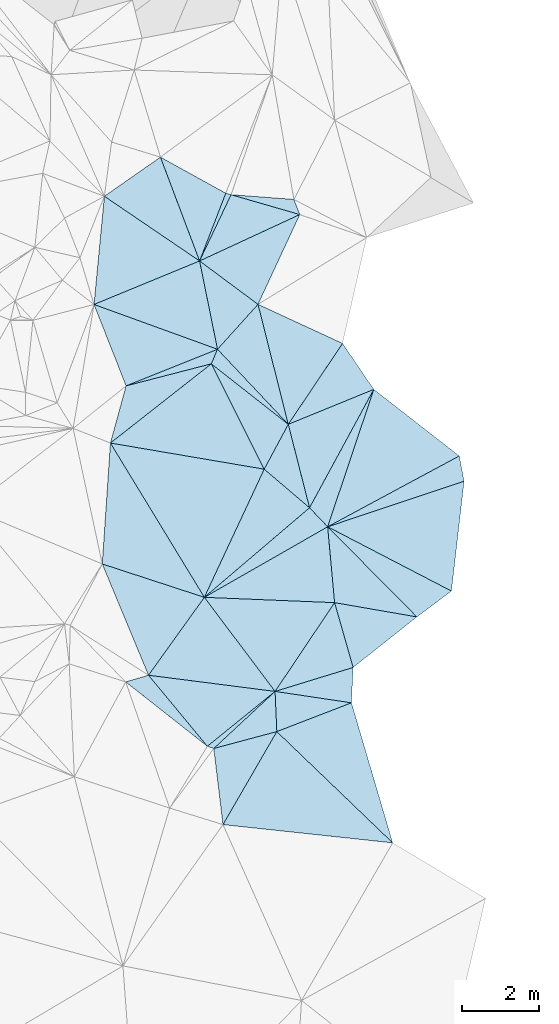
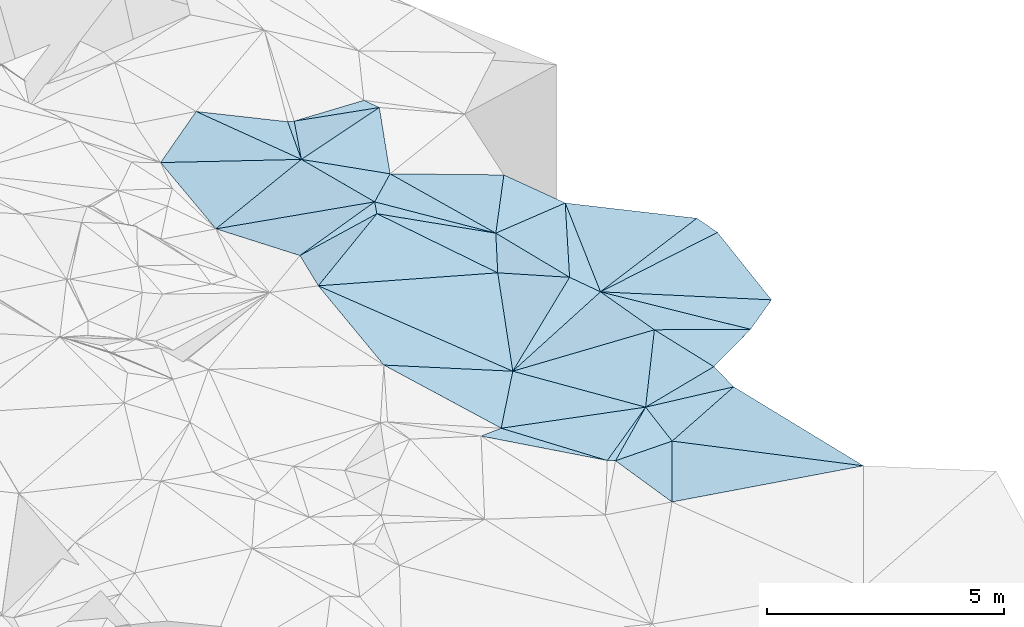
# One storey, part 159 of 275: 45 plates.
"""IFC2X3 building model written with IfcOpenShell, lengths in millimetres."""

import ifcopenshell
import ifcopenshell.guid

model = None  # the IFC model being written
_history = None  # IfcOwnerHistory: only IFC2X3 demands one
_inside = {}  # id of a spatial element -> (the spatial element, [elements in it])
_under = {}  # id of a project, library or spatial element -> (it, [spatial elements below it])
_declared = {}  # id of a project -> (the project, [libraries it declares])
_typed = {}  # id of a type object -> (the type object, [elements of that type])
_made_of = {}  # id of a material, layer set ... -> (it, [elements and type objects made of it])


def new_model(schema):
    """Start an empty IFC model of exactly this schema.

    Asked for "IFC4X3", IfcOpenShell would pick the latest addendum, in which some entities
    have other attributes; the version numbers below select the first issue.
    IFC2X3 requires an IfcOwnerHistory on every rooted entity: one is made here for all.
    """
    global model, _history
    if schema == "IFC4X3":
        model = ifcopenshell.file(schema_version=(4, 3, 0, 0))
    else:
        model = ifcopenshell.file(schema=schema)
    _inside.clear()
    _under.clear()
    _declared.clear()
    _typed.clear()
    _made_of.clear()
    _history = None
    if model.schema == "IFC2X3":
        org = make("IfcOrganization", Name="unknown")
        user = make(
            "IfcPersonAndOrganization",
            ThePerson=make("IfcPerson", FamilyName="unknown"),
            TheOrganization=org,
        )
        app = make(
            "IfcApplication",
            ApplicationDeveloper=org,
            Version="unknown",
            ApplicationFullName="unknown",
            ApplicationIdentifier="unknown",
        )
        _history = make(
            "IfcOwnerHistory",
            OwningUser=user,
            OwningApplication=app,
            ChangeAction="ADDED",
            CreationDate=0,
        )
    return model


def make(cls, **values):
    """One entity of the class cls with the attributes given. An attribute that is None is left unset."""
    return model.create_entity(
        cls, **{name: value for name, value in values.items() if value is not None}
    )


def rooted(cls, **values):
    """An entity with a GlobalId (a new one), such as an element, a storey or a relation."""
    return make(cls, GlobalId=ifcopenshell.guid.new(), OwnerHistory=_history, **values)


def si_unit(unit_type, name, prefix=None):
    """IfcSIUnit, for example si_unit("LENGTHUNIT", "METRE", prefix="MILLI")."""
    return make("IfcSIUnit", UnitType=unit_type, Prefix=prefix, Name=name)


def assignment(units):
    """IfcUnitAssignment: the units of a project."""
    return None if units is None else make("IfcUnitAssignment", Units=units)


def point(xyz):
    """IfcCartesianPoint."""
    return None if xyz is None else make("IfcCartesianPoint", Coordinates=xyz)


def direction(xyz):
    """IfcDirection."""
    return None if xyz is None else make("IfcDirection", DirectionRatios=xyz)


def frame(location, z_axis=None, x_axis=None):
    """IfcAxis2Placement3D, a coordinate frame: its origin and axes. An axis left out is left unset."""
    return make(
        "IfcAxis2Placement3D",
        Location=point(location),
        Axis=direction(z_axis),
        RefDirection=direction(x_axis),
    )


def origin_with_axes():
    """The frame at (0, 0, 0) with the z axis (0, 0, 1) and the x axis (1, 0, 0) written out."""
    return frame((0.0, 0.0, 0.0), z_axis=(0.0, 0.0, 1.0), x_axis=(1.0, 0.0, 0.0))


def place(relative_to, where):
    """IfcLocalPlacement: puts the frame where relative to a parent placement (None: the world)."""
    return make(
        "IfcLocalPlacement", PlacementRelTo=relative_to, RelativePlacement=where
    )


def context(
    kind, dimensions, precision=None, world=None, true_north=None, identifier=None
):
    """IfcGeometricRepresentationContext, for example the 3D "Model" context."""
    return make(
        "IfcGeometricRepresentationContext",
        ContextIdentifier=identifier,
        ContextType=kind,
        CoordinateSpaceDimension=dimensions,
        Precision=precision,
        WorldCoordinateSystem=world,
        TrueNorth=true_north,
    )


def subcontext(parent, identifier, kind, view, scale=None):
    """IfcGeometricRepresentationSubContext, for example "Body" below "Model"."""
    return make(
        "IfcGeometricRepresentationSubContext",
        ContextIdentifier=identifier,
        ContextType=kind,
        ParentContext=parent,
        TargetScale=scale,
        TargetView=view,
    )


def project(units=None, contexts=None):
    """IfcProject with its units and contexts."""
    return rooted(
        "IfcProject",
        Name="project",
        RepresentationContexts=contexts,
        UnitsInContext=assignment(units),
    )


def spatial(cls, under=None, at=None, **own):
    """A site, building, storey or space (cls), placed at a placement, below another one or the project."""
    s = rooted(cls, ObjectPlacement=at, **own)
    if under is not None:
        _under.setdefault(under.id(), (under, []))[1].append(s)
    return s


def polyline(points):
    """IfcPolyline through the points."""
    return make("IfcPolyline", Points=[point(p) for p in points])


def outline(outer, holes=None, kind="AREA"):
    """IfcArbitraryClosedProfileDef: a profile drawn as a closed curve; with holes, ...WithVoids."""
    if holes is None:
        return make("IfcArbitraryClosedProfileDef", ProfileType=kind, OuterCurve=outer)
    return make(
        "IfcArbitraryProfileDefWithVoids",
        ProfileType=kind,
        OuterCurve=outer,
        InnerCurves=holes,
    )


def extrude(swept, where, along, depth):
    """IfcExtrudedAreaSolid: the profile swept, set in the frame where, extruded along a direction by depth."""
    return make(
        "IfcExtrudedAreaSolid",
        SweptArea=swept,
        Position=where,
        ExtrudedDirection=direction(along),
        Depth=depth,
    )


def shape(context_of_items, identifier, shape_type, items):
    """IfcShapeRepresentation: the items that make up one representation, for example the "Body"."""
    return make(
        "IfcShapeRepresentation",
        ContextOfItems=context_of_items,
        RepresentationIdentifier=identifier,
        RepresentationType=shape_type,
        Items=items,
    )


def material(Name=None, Category=None):
    """IfcMaterial."""
    return make("IfcMaterial", Name=Name, Category=Category)


def made_of(thing, what):
    """Note that an element or type object is made of a material, layer set ...; save() writes the relation."""
    if what is not None:
        _made_of.setdefault(what.id(), (what, []))[1].append(thing)
    return thing


def type_object(cls, material=None, **own):
    """A type object (cls), such as IfcWallType, which elements share."""
    return made_of(rooted(cls, **own), material)


def element(
    cls,
    number,
    at=None,
    inside=None,
    cuts=None,
    type_object=None,
    material=None,
    context=None,
    identifier="Body",
    shape_type=None,
    held_by="IfcProductDefinitionShape",
    body=None,
    shapes=None,
    **own,
):
    """One element of the class cls, such as IfcWall. Its Tag is "e" and its number.

    at: its placement. inside: the storey or other place that contains it. cuts: it is an
    opening in that element (IfcRelVoidsElement). A single representation is given by context,
    identifier, shape_type and body (its items); several are given by shapes. held_by: the class
    of the entity that holds the representations. save() writes the other relations.
    """
    e = rooted(cls, Tag="e%d" % number, ObjectPlacement=at, **own)
    if body is not None:
        shapes = [shape(context, identifier, shape_type, body)]
    if shapes is not None:
        e.Representation = make(held_by, Representations=shapes)
    if inside is not None:
        _inside.setdefault(inside.id(), (inside, []))[1].append(e)
    if cuts is not None:
        rooted(
            "IfcRelVoidsElement", RelatingBuildingElement=cuts, RelatedOpeningElement=e
        )
    if type_object is not None:
        _typed.setdefault(type_object.id(), (type_object, []))[1].append(e)
    return made_of(e, material)


def aggregate(whole, parts):
    """IfcRelAggregates: a whole, such as a stair, and the parts it consists of."""
    return rooted("IfcRelAggregates", RelatingObject=whole, RelatedObjects=parts)


def save(model, path):
    """Write the relations noted so far, then the file.

    IfcRelAggregates (storeys below a building ...), IfcRelContainedInSpatialStructure (elements
    in a storey), IfcRelDefinesByType, IfcRelAssociatesMaterial and IfcRelDeclares: one each for
    every whole, place, type object, material and project.
    """
    for whole, parts in _under.values():
        aggregate(whole, parts)
    for where, things in _inside.values():
        rooted(
            "IfcRelContainedInSpatialStructure",
            RelatedElements=things,
            RelatingStructure=where,
        )
    for kind, things in _typed.values():
        rooted("IfcRelDefinesByType", RelatedObjects=things, RelatingType=kind)
    for what, things in _made_of.values():
        rooted("IfcRelAssociatesMaterial", RelatedObjects=things, RelatingMaterial=what)
    for by, libraries in _declared.values():
        rooted("IfcRelDeclares", RelatingContext=by, RelatedDefinitions=libraries)
    model.write(path)


model = new_model("IFC2X3")

# Units and contexts
model_context = context("Model", 3, precision=1e-05, world=origin_with_axes())
body_context = subcontext(model_context, "Body", "Model", "MODEL_VIEW")
ifc_project = project(units=[si_unit("LENGTHUNIT", "METRE", prefix="MILLI"), si_unit("AREAUNIT", "SQUARE_METRE"), si_unit("VOLUMEUNIT", "CUBIC_METRE"), si_unit("MASSUNIT", "GRAM", prefix="KILO"), si_unit("TIMEUNIT", "SECOND"), si_unit("PLANEANGLEUNIT", "RADIAN"), si_unit("SOLIDANGLEUNIT", "STERADIAN"), si_unit("THERMODYNAMICTEMPERATUREUNIT", "DEGREE_CELSIUS"), si_unit("LUMINOUSINTENSITYUNIT", "LUMEN")], contexts=[model_context])

# Site, building, storey
site_placement = place(None, origin_with_axes())
site = spatial("IfcSite", under=ifc_project, at=site_placement, CompositionType="ELEMENT")
building_placement = place(site_placement, origin_with_axes())
building = spatial("IfcBuilding", under=site, at=building_placement, Name="Undefined", CompositionType="ELEMENT")
storey_placement = place(building_placement, origin_with_axes())
storey = spatial("IfcBuildingStorey", under=building, at=storey_placement, Name="Undefined", CompositionType="ELEMENT", Elevation=0.0)

# Plates
ifc_material = material()
plate_type_1 = type_object("IfcPlateType", PredefinedType="NOTDEFINED")
plate_1_placement = place(storey_placement, frame((-33080.2540832994, 129754.297302444, 45919.5141620709), z_axis=(-0.214587577699776, -0.0988065325564838, -0.971694108565606), x_axis=(0.797473107325296, -0.592117404051105, -0.115903506904312)))
element("IfcPlate", 1, at=plate_1_placement, inside=storey, type_object=plate_type_1, material=ifc_material, Name="00", context=body_context, shape_type="SweptSolid", body=[
    extrude(outline(polyline([(0.0, 0.0), (1898.13061523438, -3.92901711165905e-09), (1709.89282226563, 1594.22912597656), (0.0, 0.0)])), frame((-8.85201319254618e-08, 2.18876761149539e-07, -0.5000001331573), z_axis=(0.0, 0.0, 1.0), x_axis=(1.0, 0.0, 0.0)), (0.0, 0.0, 1.0), 1.0),
])
plate_2_placement = place(storey_placement, frame((-27451.008393185, 120533.023808018, 45159.5179466628), z_axis=(-0.247378094575524, -0.0962454606016456, -0.964127009080111), x_axis=(-0.958999822656448, 0.166338762885519, 0.229457525713618)))
element("IfcPlate", 2, at=plate_2_placement, inside=storey, type_object=plate_type_1, material=ifc_material, Name="00", context=body_context, shape_type="SweptSolid", body=[
    extrude(outline(polyline([(0.0, 0.0), (2222.63354492188, 1.30967237055302e-09), (2687.62255859375, 1923.560546875), (0.0, 0.0)])), frame((-8.85201319254618e-08, 2.18876761149539e-07, -0.5000001331573), z_axis=(0.0, 0.0, 1.0), x_axis=(1.0, 0.0, 0.0)), (0.0, 0.0, 1.0), 1.0),
])
plate_type_2 = type_object("IfcPlateType", PredefinedType="NOTDEFINED")
plate_3_placement = place(storey_placement, frame((-32615.5109748001, 127466.84957414, 46049.5017491247), z_axis=(0.0719724589365556, -0.0420154660429778, -0.996521282144951), x_axis=(-0.936910517217906, 0.339816973030889, -0.081994558152361)))
element("IfcPlate", 3, at=plate_3_placement, inside=storey, type_object=plate_type_2, material=ifc_material, Name="00", context=body_context, shape_type="SweptSolid", body=[
    extrude(outline(polyline([(0.0, 0.0), (3414.86083984375, 6.83940015733242e-10), (1223.27099609375, 1992.2119140625), (0.0, 0.0)])), frame((-8.85201319254618e-08, 2.18876761149539e-07, -0.5000001331573), z_axis=(0.0, 0.0, 1.0), x_axis=(1.0, 0.0, 0.0)), (0.0, 0.0, 1.0), 1.0),
])
plate_type_3 = type_object("IfcPlateType", PredefinedType="NOTDEFINED")
plate_4_placement = place(storey_placement, frame((-31079.5214193019, 117562.126037099, 45349.5046864779), z_axis=(-0.0836903103693384, -0.107779366521294, -0.990646021595278), x_axis=(0.721234976952968, -0.692540457884973, 0.0144160400985565)))
element("IfcPlate", 4, at=plate_4_placement, inside=storey, type_object=plate_type_3, material=ifc_material, Name="00", context=body_context, shape_type="SweptSolid", body=[
    extrude(outline(polyline([(0.0, 0.0), (4162.03076171875, 2.15586624108255e-08), (668.375671386719, 2729.42749023438), (0.0, 0.0)])), frame((-8.85201319254618e-08, 2.18876761149539e-07, -0.5000001331573), z_axis=(0.0, 0.0, 1.0), x_axis=(1.0, 0.0, 0.0)), (0.0, 0.0, 1.0), 1.0),
])
plate_type_4 = type_object("IfcPlateType", PredefinedType="NOTDEFINED")
plate_5_placement = place(storey_placement, frame((-30782.6319022427, 125521.966014984, 45779.5025610777), z_axis=(-0.062351404082523, 0.0793517939533565, -0.994894765895028), x_axis=(-0.782383875998877, 0.615023951928087, 0.0980867428949059)))
element("IfcPlate", 5, at=plate_5_placement, inside=storey, type_object=plate_type_4, material=ifc_material, Name="00", context=body_context, shape_type="SweptSolid", body=[
    extrude(outline(polyline([(0.0, 0.0), (2548.76440429688, -8.45466274768114e-09), (2656.73828125, 396.410949707031), (0.0, 0.0)])), frame((-8.85201319254618e-08, 2.18876761149539e-07, -0.5000001331573), z_axis=(0.0, 0.0, 1.0), x_axis=(1.0, 0.0, 0.0)), (0.0, 0.0, 1.0), 1.0),
])
plate_type_5 = type_object("IfcPlateType", PredefinedType="NOTDEFINED")
plate_6_placement = place(storey_placement, frame((-34094.3858225405, 132443.915506751, 45879.5147112208), z_axis=(-0.220117672743664, -0.09743077703448, -0.97059541201902), x_axis=(0.865580341219619, -0.478311033943339, -0.148287651887071)))
element("IfcPlate", 6, at=plate_6_placement, inside=storey, type_object=plate_type_5, material=ifc_material, Name="00", context=body_context, shape_type="SweptSolid", body=[
    extrude(outline(polyline([(0.0, 0.0), (1955.65844726563, 5.06406649947166e-09), (2158.35229492188, 1898.845703125), (0.0, 0.0)])), frame((-8.85201319254618e-08, 2.18876761149539e-07, -0.5000001331573), z_axis=(0.0, 0.0, 1.0), x_axis=(1.0, 0.0, 0.0)), (0.0, 0.0, 1.0), 1.0),
])
plate_type_6 = type_object("IfcPlateType", PredefinedType="NOTDEFINED")
plate_7_placement = place(storey_placement, frame((-30484.574847543, 130956.504628623, 45619.5001934951), z_axis=(0.0252871807435441, 0.00976952494033575, -0.999632489904407), x_axis=(-0.960487748180554, 0.277483999919853, -0.0215850731647423)))
element("IfcPlate", 7, at=plate_7_placement, inside=storey, type_object=plate_type_6, material=ifc_material, Name="00", context=body_context, shape_type="SweptSolid", body=[
    extrude(outline(polyline([(0.0, 0.0), (1853.13244628906, -4.97675500810146e-09), (254.380081176758, 334.799591064453), (0.0, 0.0)])), frame((-8.85201319254618e-08, 2.18876761149539e-07, -0.5000001331573), z_axis=(0.0, 0.0, 1.0), x_axis=(1.0, 0.0, 0.0)), (0.0, 0.0, 1.0), 1.0),
])
plate_type_7 = type_object("IfcPlateType", PredefinedType="NOTDEFINED")
plate_8_placement = place(storey_placement, frame((-32264.5135595346, 131470.624122395, 45579.5084487931), z_axis=(-0.0300443538269851, -0.180471585213477, -0.983121225349984), x_axis=(0.960487748181459, -0.27748399991637, 0.0215850731692638)))
element("IfcPlate", 8, at=plate_8_placement, inside=storey, type_object=plate_type_7, material=ifc_material, Name="00", context=body_context, shape_type="SweptSolid", body=[
    extrude(outline(polyline([(0.0, 0.0), (1853.13244628906, -4.97675500810146e-09), (-299.816650390625, 1907.06848144531), (0.0, 0.0)])), frame((-8.85201319254618e-08, 2.18876761149539e-07, -0.5000001331573), z_axis=(0.0, 0.0, 1.0), x_axis=(1.0, 0.0, 0.0)), (0.0, 0.0, 1.0), 1.0),
])
plate_type_8 = type_object("IfcPlateType", PredefinedType="NOTDEFINED")
plate_9_placement = place(storey_placement, frame((-30484.6504729716, 130956.511985596, 45619.5041431911), z_axis=(-0.125963108733324, 0.0244767861941416, -0.991732918771906), x_axis=(-0.421512530736581, -0.906286728735304, 0.0311697248993892)))
element("IfcPlate", 9, at=plate_9_placement, inside=storey, type_object=plate_type_8, material=ifc_material, Name="00", context=body_context, shape_type="SweptSolid", body=[
    extrude(outline(polyline([(0.0, 0.0), (2566.59301757813, -4.80213202536106e-10), (2192.90698242188, 1860.98327636719), (0.0, 0.0)])), frame((-8.85201319254618e-08, 2.18876761149539e-07, -0.5000001331573), z_axis=(0.0, 0.0, 1.0), x_axis=(1.0, 0.0, 0.0)), (0.0, 0.0, 1.0), 1.0),
])
plate_10_placement = place(storey_placement, frame((-33080.0899119681, 129754.360760875, 45919.5034532117), z_axis=(0.113735607202041, 0.0281147961050572, -0.993113170738539), x_axis=(-0.824547559893915, 0.560310909872546, -0.0785684780989904)))
element("IfcPlate", 10, at=plate_10_placement, inside=storey, type_object=plate_type_8, material=ifc_material, Name="00", context=body_context, shape_type="SweptSolid", body=[
    extrude(outline(polyline([(0.0, 0.0), (2991.021484375, 4.08908817917109e-09), (2346.3623046875, 1660.92858886719), (0.0, 0.0)])), frame((-8.85201319254618e-08, 2.18876761149539e-07, -0.5000001331573), z_axis=(0.0, 0.0, 1.0), x_axis=(1.0, 0.0, 0.0)), (0.0, 0.0, 1.0), 1.0),
])
plate_type_9 = type_object("IfcPlateType", PredefinedType="NOTDEFINED")
plate_11_placement = place(storey_placement, frame((-31566.491751504, 128630.404338631, 45699.5035285261), z_axis=(-0.10624652814122, -0.0523457360185478, -0.992961026011904), x_axis=(0.905145965336065, -0.418470127042266, -0.0747899338753069)))
element("IfcPlate", 11, at=plate_11_placement, inside=storey, type_object=plate_type_9, material=ifc_material, Name="00", context=body_context, shape_type="SweptSolid", body=[
    extrude(outline(polyline([(0.0, 0.0), (2420.11181640625, 2.3283064365387e-09), (2004.32067871094, 2503.25756835938), (0.0, 0.0)])), frame((-8.85201319254618e-08, 2.18876761149539e-07, -0.5000001331573), z_axis=(0.0, 0.0, 1.0), x_axis=(1.0, 0.0, 0.0)), (0.0, 0.0, 1.0), 1.0),
])
plate_type_10 = type_object("IfcPlateType", PredefinedType="NOTDEFINED")
plate_12_placement = place(storey_placement, frame((-26353.2871981632, 124702.97882103, 45109.5033784448), z_axis=(-0.115676906851437, -0.00702153310631473, -0.993262075836041), x_axis=(0.188309568029457, -0.981995335002181, -0.0149889500137031)))
element("IfcPlate", 12, at=plate_12_placement, inside=storey, type_object=plate_type_10, material=ifc_material, Name="00", context=body_context, shape_type="SweptSolid", body=[
    extrude(outline(polyline([(0.0, 0.0), (667.158142089844, -2.18278728425503e-09), (1153.99926757813, 3718.3310546875), (0.0, 0.0)])), frame((-8.85201319254618e-08, 2.18876761149539e-07, -0.5000001331573), z_axis=(0.0, 0.0, 1.0), x_axis=(1.0, 0.0, 0.0)), (0.0, 0.0, 1.0), 1.0),
])
plate_type_11 = type_object("IfcPlateType", PredefinedType="NOTDEFINED")
plate_13_placement = place(storey_placement, frame((-32474.315049607, 115152.427456265, 45729.5092768499), z_axis=(-0.185726669026106, -0.0472730703458311, -0.981463632149733), x_axis=(-0.119657105994302, 0.992496392583434, -0.0251612339510379)))
element("IfcPlate", 13, at=plate_13_placement, inside=storey, type_object=plate_type_11, material=ifc_material, Name="00", context=body_context, shape_type="SweptSolid", body=[
    extrude(outline(polyline([(0.0, 0.0), (1987.18395996094, -1.16488081403077e-08), (2234.31762695313, 1704.2080078125), (0.0, 0.0)])), frame((-8.85201319254618e-08, 2.18876761149539e-07, -0.5000001331573), z_axis=(0.0, 0.0, 1.0), x_axis=(1.0, 0.0, 0.0)), (0.0, 0.0, 1.0), 1.0),
])
plate_type_12 = type_object("IfcPlateType", PredefinedType="NOTDEFINED")
plate_14_placement = place(storey_placement, frame((-35814.9309706357, 128627.279765097, 45769.5015723026), z_axis=(0.0698948741740806, -0.0369276431656723, -0.996870631393271), x_axis=(0.0953400579687843, 0.994987363014564, -0.0301731799423541)))
element("IfcPlate", 14, at=plate_14_placement, inside=storey, type_object=plate_type_12, material=ifc_material, Name="00", context=body_context, shape_type="SweptSolid", body=[
    extrude(outline(polyline([(0.0, 0.0), (2817.0712890625, 3.86207830160856e-08), (1377.61083984375, 2621.8623046875), (0.0, 0.0)])), frame((-8.85201319254618e-08, 2.18876761149539e-07, -0.5000001331573), z_axis=(0.0, 0.0, 1.0), x_axis=(1.0, 0.0, 0.0)), (0.0, 0.0, 1.0), 1.0),
])
plate_type_13 = type_object("IfcPlateType", PredefinedType="NOTDEFINED")
plate_15_placement = place(storey_placement, frame((-32776.7330475096, 127089.53108983, 46029.5032967244), z_axis=(-0.0402925760040155, 0.10717853352685, -0.99342300671466), x_axis=(0.782383875994924, -0.615023951933998, -0.0980867428893799)))
element("IfcPlate", 15, at=plate_15_placement, inside=storey, type_object=plate_type_13, material=ifc_material, Name="00", context=body_context, shape_type="SweptSolid", body=[
    extrude(outline(polyline([(0.0, 0.0), (2548.76440429688, -8.45466274768114e-09), (2784.87890625, 1300.74975585938), (0.0, 0.0)])), frame((-8.85201319254618e-08, 2.18876761149539e-07, -0.5000001331573), z_axis=(0.0, 0.0, 1.0), x_axis=(1.0, 0.0, 0.0)), (0.0, 0.0, 1.0), 1.0),
])
plate_type_14 = type_object("IfcPlateType", PredefinedType="NOTDEFINED")
plate_16_placement = place(storey_placement, frame((-32776.7891746376, 127089.50249325, 46029.5064926775), z_axis=(-0.152546925141533, 0.0499852325733164, -0.987031363308408), x_axis=(0.445862833855377, -0.88782877859886, -0.113870071915797)))
element("IfcPlate", 16, at=plate_16_placement, inside=storey, type_object=plate_type_14, material=ifc_material, Name="00", context=body_context, shape_type="SweptSolid", body=[
    extrude(outline(polyline([(0.0, 0.0), (3073.67846679688, -4.13274392485619e-09), (622.381286621094, 3277.71899414063), (0.0, 0.0)])), frame((-8.85201319254618e-08, 2.18876761149539e-07, -0.5000001331573), z_axis=(0.0, 0.0, 1.0), x_axis=(1.0, 0.0, 0.0)), (0.0, 0.0, 1.0), 1.0),
])
plate_type_15 = type_object("IfcPlateType", PredefinedType="NOTDEFINED")
plate_17_placement = place(storey_placement, frame((-34984.1653656682, 126518.046743079, 46069.5043417854), z_axis=(0.0415522514183986, -0.124635044644425, -0.991332192581551), x_axis=(-0.363313745068226, 0.922383328152525, -0.131194964045011)))
element("IfcPlate", 17, at=plate_17_placement, inside=storey, type_object=plate_type_15, material=ifc_material, Name="00", context=body_context, shape_type="SweptSolid", body=[
    extrude(outline(polyline([(0.0, 0.0), (2286.67309570313, -5.89352566748858e-10), (17.1865406036377, 2551.60815429688), (0.0, 0.0)])), frame((-8.85201319254618e-08, 2.18876761149539e-07, -0.5000001331573), z_axis=(0.0, 0.0, 1.0), x_axis=(1.0, 0.0, 0.0)), (0.0, 0.0, 1.0), 1.0),
])
plate_type_16 = type_object("IfcPlateType", PredefinedType="NOTDEFINED")
plate_18_placement = place(storey_placement, frame((-35390.1717472726, 125037.422963012, 46329.5084402184), z_axis=(0.0289242037191253, -0.180574971835113, -0.983135834961763), x_axis=(0.260739034977015, 0.950859751984201, -0.166975709897576)))
element("IfcPlate", 18, at=plate_18_placement, inside=storey, type_object=plate_type_16, material=ifc_material, Name="00", context=body_context, shape_type="SweptSolid", body=[
    extrude(outline(polyline([(0.0, 0.0), (1557.11267089844, -9.59698809310794e-09), (2682.65747070313, 1983.46899414063), (0.0, 0.0)])), frame((-8.85201319254618e-08, 2.18876761149539e-07, -0.5000001331573), z_axis=(0.0, 0.0, 1.0), x_axis=(1.0, 0.0, 0.0)), (0.0, 0.0, 1.0), 1.0),
])
plate_type_17 = type_object("IfcPlateType", PredefinedType="NOTDEFINED")
plate_19_placement = place(storey_placement, frame((-31406.2513660793, 124360.563691876, 45679.5006978037), z_axis=(0.0449943966113469, -0.0270185902874154, -0.998621800309037), x_axis=(0.760344416629182, -0.647453185632179, 0.0517758680813033)))
element("IfcPlate", 19, at=plate_19_placement, inside=storey, type_object=plate_type_17, material=ifc_material, Name="00", context=body_context, shape_type="SweptSolid", body=[
    extrude(outline(polyline([(0.0, 0.0), (1545.12133789063, -3.37604433298111e-09), (972.286071777344, 3532.81176757813), (0.0, 0.0)])), frame((-8.85201319254618e-08, 2.18876761149539e-07, -0.5000001331573), z_axis=(0.0, 0.0, 1.0), x_axis=(1.0, 0.0, 0.0)), (0.0, 0.0, 1.0), 1.0),
])
plate_type_18 = type_object("IfcPlateType", PredefinedType="NOTDEFINED")
plate_20_placement = place(storey_placement, frame((-29145.8099262018, 118307.683269759, 45619.5007519367), z_axis=(-0.00306853389549542, -0.0543729903167783, -0.998515979853975), x_axis=(-0.989030891286989, 0.147624194994125, -0.00499931319282602)))
element("IfcPlate", 20, at=plate_20_placement, inside=storey, type_object=plate_type_18, material=ifc_material, Name="00", context=body_context, shape_type="SweptSolid", body=[
    extrude(outline(polyline([(0.0, 0.0), (2000.27502441406, 4.8748916015029e-09), (92.4872817993164, 913.480224609375), (0.0, 0.0)])), frame((-8.85201319254618e-08, 2.18876761149539e-07, -0.5000001331573), z_axis=(0.0, 0.0, 1.0), x_axis=(1.0, 0.0, 0.0)), (0.0, 0.0, 1.0), 1.0),
])
plate_type_19 = type_object("IfcPlateType", PredefinedType="NOTDEFINED")
plate_21_placement = place(storey_placement, frame((-32956.1965949455, 121040.417674552, 45699.5067117253), z_axis=(-0.150075249696888, 0.0641113325937297, -0.986593713978289), x_axis=(-0.515458031278642, 0.846465412353808, 0.133414105997242)))
element("IfcPlate", 21, at=plate_21_placement, inside=storey, type_object=plate_type_19, material=ifc_material, Name="00", context=body_context, shape_type="SweptSolid", body=[
    extrude(outline(polyline([(0.0, 0.0), (4722.13916015625, 1.93685991689563e-08), (2008.87756347656, 3064.39404296875), (0.0, 0.0)])), frame((-8.85201319254618e-08, 2.18876761149539e-07, -0.5000001331573), z_axis=(0.0, 0.0, 1.0), x_axis=(1.0, 0.0, 0.0)), (0.0, 0.0, 1.0), 1.0),
])
plate_type_20 = type_object("IfcPlateType", PredefinedType="NOTDEFINED")
plate_22_placement = place(storey_placement, frame((-30231.5517110866, 123360.315732632, 45759.5287885653), z_axis=(-0.204488088261564, 0.264553005860469, -0.942441684588135), x_axis=(0.650516951480907, -0.68270034638169, -0.33278812010994)))
element("IfcPlate", 22, at=plate_22_placement, inside=storey, type_object=plate_type_20, material=ifc_material, Name="00", context=body_context, shape_type="SweptSolid", body=[
    extrude(outline(polyline([(0.0, 0.0), (721.179565429688, 1.43336364999413e-09), (-168.751312255859, 3574.9716796875), (0.0, 0.0)])), frame((-8.85201319254618e-08, 2.18876761149539e-07, -0.5000001331573), z_axis=(0.0, 0.0, 1.0), x_axis=(1.0, 0.0, 0.0)), (0.0, 0.0, 1.0), 1.0),
])
plate_type_21 = type_object("IfcPlateType", PredefinedType="NOTDEFINED")
plate_23_placement = place(storey_placement, frame((-30231.4012004996, 123360.200363664, 45759.5026319646), z_axis=(0.0965323889209722, 0.0338148697749852, -0.994755272653184), x_axis=(-0.76034441661179, 0.647453185651802, -0.0517758680913277)))
element("IfcPlate", 23, at=plate_23_placement, inside=storey, type_object=plate_type_21, material=ifc_material, Name="00", context=body_context, shape_type="SweptSolid", body=[
    extrude(outline(polyline([(0.0, 0.0), (1545.12133789063, -3.37604433298111e-09), (1817.65661621094, 1293.60913085938), (0.0, 0.0)])), frame((-8.85201319254618e-08, 2.18876761149539e-07, -0.5000001331573), z_axis=(0.0, 0.0, 1.0), x_axis=(1.0, 0.0, 0.0)), (0.0, 0.0, 1.0), 1.0),
])
plate_type_22 = type_object("IfcPlateType", PredefinedType="NOTDEFINED")
plate_24_placement = place(storey_placement, frame((-29582.3959131309, 120902.74344647, 45669.5015379628), z_axis=(-0.0120138072821194, -0.0772005093065289, -0.996943202894428), x_axis=(-0.999129821489127, 0.0407512649952192, 0.00888449280456197)))
element("IfcPlate", 24, at=plate_24_placement, inside=storey, type_object=plate_type_22, material=ifc_material, Name="00", context=body_context, shape_type="SweptSolid", body=[
    extrude(outline(polyline([(0.0, 0.0), (3376.669921875, 2.56113708019257e-09), (258.509124755859, 1962.00744628906), (0.0, 0.0)])), frame((-8.85201319254618e-08, 2.18876761149539e-07, -0.5000001331573), z_axis=(0.0, 0.0, 1.0), x_axis=(1.0, 0.0, 0.0)), (0.0, 0.0, 1.0), 1.0),
])
plate_type_23 = type_object("IfcPlateType", PredefinedType="NOTDEFINED")
plate_25_placement = place(storey_placement, frame((-29762.3565644255, 122867.809466454, 45519.5027902274), z_axis=(-0.0932920531370409, -0.0488678624782353, -0.99443879894053), x_axis=(0.31735835000271, 0.945237424019144, -0.076222633890533)))
element("IfcPlate", 25, at=plate_25_placement, inside=storey, type_object=plate_type_23, material=ifc_material, Name="00", context=body_context, shape_type="SweptSolid", body=[
    extrude(outline(polyline([(0.0, 0.0), (3765.28588867188, 1.88738340511918e-08), (2847.80249023438, 2654.75439453125), (0.0, 0.0)])), frame((-8.85201319254618e-08, 2.18876761149539e-07, -0.5000001331573), z_axis=(0.0, 0.0, 1.0), x_axis=(1.0, 0.0, 0.0)), (0.0, 0.0, 1.0), 1.0),
])
plate_type_24 = type_object("IfcPlateType", PredefinedType="NOTDEFINED")
plate_26_placement = place(storey_placement, frame((-26555.1041273474, 121202.44714521, 45199.503204639), z_axis=(-0.110656100001053, -0.0221856579488268, -0.99361110305488), x_axis=(-0.884029540129614, 0.459033807016233, 0.0882028128486171)))
element("IfcPlate", 26, at=plate_26_placement, inside=storey, type_object=plate_type_24, material=ifc_material, Name="00", context=body_context, shape_type="SweptSolid", body=[
    extrude(outline(polyline([(0.0, 0.0), (3628.00219726563, -4.40923031419516e-09), (1007.82739257813, 2682.84985351563), (0.0, 0.0)])), frame((-8.85201319254618e-08, 2.18876761149539e-07, -0.5000001331573), z_axis=(0.0, 0.0, 1.0), x_axis=(1.0, 0.0, 0.0)), (0.0, 0.0, 1.0), 1.0),
])
plate_type_25 = type_object("IfcPlateType", PredefinedType="NOTDEFINED")
plate_27_placement = place(storey_placement, frame((-35390.2842031174, 125037.530807772, 46329.5100197485), z_axis=(-0.19598623408579, 0.0351109355445252, -0.979977866206201), x_axis=(0.515458031290571, -0.846465412346784, -0.133414105995719)))
element("IfcPlate", 27, at=plate_27_placement, inside=storey, type_object=plate_type_25, material=ifc_material, Name="00", context=body_context, shape_type="SweptSolid", body=[
    extrude(outline(polyline([(0.0, 0.0), (4722.13916015625, 1.93685991689563e-08), (2552.38134765625, 1830.36877441406), (0.0, 0.0)])), frame((-8.85201319254618e-08, 2.18876761149539e-07, -0.5000001331573), z_axis=(0.0, 0.0, 1.0), x_axis=(1.0, 0.0, 0.0)), (0.0, 0.0, 1.0), 1.0),
])
plate_type_26 = type_object("IfcPlateType", PredefinedType="NOTDEFINED")
plate_28_placement = place(storey_placement, frame((-29582.4073711371, 120902.806779442, 45669.5009270347), z_axis=(-0.03492619348906, 0.0494557456420015, -0.998165462351487), x_axis=(0.274380295119216, -0.959920837209529, -0.0571615250080844)))
element("IfcPlate", 28, at=plate_28_placement, inside=storey, type_object=plate_type_26, material=ifc_material, Name="00", context=body_context, shape_type="SweptSolid", body=[
    extrude(outline(polyline([(0.0, 0.0), (1749.42846679688, 4.92354956804775e-09), (1788.01245117188, 2114.85498046875), (0.0, 0.0)])), frame((-8.85201319254618e-08, 2.18876761149539e-07, -0.5000001331573), z_axis=(0.0, 0.0, 1.0), x_axis=(1.0, 0.0, 0.0)), (0.0, 0.0, 1.0), 1.0),
])
plate_type_27 = type_object("IfcPlateType", PredefinedType="NOTDEFINED")
plate_29_placement = place(storey_placement, frame((-31124.1459477125, 118603.01503218, 45609.5002669538), z_axis=(-0.00761585294834229, 0.0311815746232608, -0.999484721337892), x_axis=(-0.600565068299224, 0.799031356306091, 0.0295040739288025)))
element("IfcPlate", 29, at=plate_29_placement, inside=storey, type_object=plate_type_27, material=ifc_material, Name="00", context=body_context, shape_type="SweptSolid", body=[
    extrude(outline(polyline([(0.0, 0.0), (3050.42626953125, -4.91127138957381e-09), (913.446105957031, 2614.42456054688), (0.0, 0.0)])), frame((-8.85201319254618e-08, 2.18876761149539e-07, -0.5000001331573), z_axis=(0.0, 0.0, 1.0), x_axis=(1.0, 0.0, 0.0)), (0.0, 0.0, 1.0), 1.0),
])
plate_type_28 = type_object("IfcPlateType", PredefinedType="NOTDEFINED")
plate_30_placement = place(storey_placement, frame((-29762.3300532426, 122867.890510754, 45519.5036324607), z_axis=(-0.0402658224515694, 0.113210799402463, -0.992754742341206), x_axis=(0.884029540136885, -0.45903380700123, -0.0882028128538157)))
element("IfcPlate", 30, at=plate_30_placement, inside=storey, type_object=plate_type_28, material=ifc_material, Name="00", context=body_context, shape_type="SweptSolid", body=[
    extrude(outline(polyline([(0.0, 0.0), (3628.00219726563, -4.40923031419516e-09), (3146.85595703125, 1010.29608154297), (0.0, 0.0)])), frame((-8.85201319254618e-08, 2.18876761149539e-07, -0.5000001331573), z_axis=(0.0, 0.0, 1.0), x_axis=(1.0, 0.0, 0.0)), (0.0, 0.0, 1.0), 1.0),
])
plate_31_placement = place(storey_placement, frame((-31079.4589315929, 117562.301821697, 45349.5155385085), z_axis=(0.0412901857495332, 0.243816572798041, -0.968942000013307), x_axis=(-0.0415956451304031, 0.969347747175732, 0.242146128095243)))
element("IfcPlate", 31, at=plate_31_placement, inside=storey, type_object=plate_type_28, material=ifc_material, Name="00", context=body_context, shape_type="SweptSolid", body=[
    extrude(outline(polyline([(0.0, 0.0), (1073.73181152344, 3.71073838323355e-10), (707.62548828125, 1966.48571777344), (0.0, 0.0)])), frame((-8.85201319254618e-08, 2.18876761149539e-07, -0.5000001331573), z_axis=(0.0, 0.0, 1.0), x_axis=(1.0, 0.0, 0.0)), (0.0, 0.0, 1.0), 1.0),
])
plate_type_29 = type_object("IfcPlateType", PredefinedType="NOTDEFINED")
plate_32_placement = place(storey_placement, frame((-30782.7310700799, 125521.953757267, 45779.5180216876), z_axis=(-0.260382905149372, 0.0547262876772139, -0.963953202257788), x_axis=(0.554359211543692, 0.825897526497399, -0.102854947873861)))
element("IfcPlate", 32, at=plate_32_placement, inside=storey, type_object=plate_type_29, material=ifc_material, Name="00", context=body_context, shape_type="SweptSolid", body=[
    extrude(outline(polyline([(0.0, 0.0), (2537.55419921875, 7.07223080098629e-09), (2031.732421875, 1377.51965332031), (0.0, 0.0)])), frame((-8.85201319254618e-08, 2.18876761149539e-07, -0.5000001331573), z_axis=(0.0, 0.0, 1.0), x_axis=(1.0, 0.0, 0.0)), (0.0, 0.0, 1.0), 1.0),
])
plate_type_30 = type_object("IfcPlateType", PredefinedType="NOTDEFINED")
plate_33_placement = place(storey_placement, frame((-29102.4982918712, 119223.464679077, 45569.5139336897), z_axis=(-0.234173517338558, -0.00904539776891151, -0.972152737257109), x_axis=(-0.274380295123693, 0.959920837208501, 0.0571615250038558)))
element("IfcPlate", 33, at=plate_33_placement, inside=storey, type_object=plate_type_30, material=ifc_material, Name="00", context=body_context, shape_type="SweptSolid", body=[
    extrude(outline(polyline([(0.0, 0.0), (1749.42846679688, 4.92354956804775e-09), (780.540649414063, 2000.33911132813), (0.0, 0.0)])), frame((-8.85201319254618e-08, 2.18876761149539e-07, -0.5000001331573), z_axis=(0.0, 0.0, 1.0), x_axis=(1.0, 0.0, 0.0)), (0.0, 0.0, 1.0), 1.0),
])
plate_type_31 = type_object("IfcPlateType", PredefinedType="NOTDEFINED")
plate_34_placement = place(storey_placement, frame((-34404.0086252239, 119022.694449016, 45959.5103346474), z_axis=(-0.201351419324163, 0.0182798405274566, -0.97934848412934), x_axis=(-0.381966198018975, 0.91920918487101, 0.0956885469620169)))
element("IfcPlate", 34, at=plate_34_placement, inside=storey, type_object=plate_type_31, material=ifc_material, Name="00", context=body_context, shape_type="SweptSolid", body=[
    extrude(outline(polyline([(0.0, 0.0), (3135.17138671875, 1.03864294942468e-08), (1276.80419921875, 2145.82641601563), (0.0, 0.0)])), frame((-8.85201319254618e-08, 2.18876761149539e-07, -0.5000001331573), z_axis=(0.0, 0.0, 1.0), x_axis=(1.0, 0.0, 0.0)), (0.0, 0.0, 1.0), 1.0),
])
plate_type_32 = type_object("IfcPlateType", PredefinedType="NOTDEFINED")
plate_35_placement = place(storey_placement, frame((-31124.2673978973, 118603.11168922, 45609.5291479024), z_axis=(-0.250517456616646, 0.224495508295163, -0.941723298366151), x_axis=(0.04159564510268, -0.969347747177357, -0.242146128093501)))
element("IfcPlate", 35, at=plate_35_placement, inside=storey, type_object=plate_type_32, material=ifc_material, Name="00", context=body_context, shape_type="SweptSolid", body=[
    extrude(outline(polyline([(0.0, 0.0), (1073.73181152344, 3.71073838323355e-10), (1349.96472167969, 1699.73388671875), (0.0, 0.0)])), frame((-8.85201319254618e-08, 2.18876761149539e-07, -0.5000001331573), z_axis=(0.0, 0.0, 1.0), x_axis=(1.0, 0.0, 0.0)), (0.0, 0.0, 1.0), 1.0),
])
plate_type_33 = type_object("IfcPlateType", PredefinedType="NOTDEFINED")
plate_36_placement = place(storey_placement, frame((-30782.711314295, 125521.90265326, 45779.5129684402), z_axis=(-0.221171678390476, -0.0473772263625393, -0.974083408697701), x_axis=(0.902450734321931, 0.368680788171714, -0.222838839870636)))
element("IfcPlate", 36, at=plate_36_placement, inside=storey, type_object=plate_type_33, material=ifc_material, Name="00", context=body_context, shape_type="SweptSolid", body=[
    extrude(outline(polyline([(0.0, 0.0), (2454.68872070313, -3.14321368932724e-09), (-295.149444580078, 2211.37670898438), (0.0, 0.0)])), frame((-8.85201319254618e-08, 2.18876761149539e-07, -0.5000001331573), z_axis=(0.0, 0.0, 1.0), x_axis=(1.0, 0.0, 0.0)), (0.0, 0.0, 1.0), 1.0),
])
plate_type_34 = type_object("IfcPlateType", PredefinedType="NOTDEFINED")
plate_37_placement = place(storey_placement, frame((-32879.4726736731, 117181.938535793, 45709.5031788792), z_axis=(-0.0992922732355133, 0.0527200262189472, -0.993660728473858), x_axis=(-0.634376577407002, 0.76599206737902, 0.104031296972559)))
element("IfcPlate", 37, at=plate_37_placement, inside=storey, type_object=plate_type_34, material=ifc_material, Name="00", context=body_context, shape_type="SweptSolid", body=[
    extrude(outline(polyline([(0.0, 0.0), (2403.123046875, 1.78988557308912e-09), (-35.3706398010254, 2260.36474609375), (0.0, 0.0)])), frame((-8.85201319254618e-08, 2.18876761149539e-07, -0.5000001331573), z_axis=(0.0, 0.0, 1.0), x_axis=(1.0, 0.0, 0.0)), (0.0, 0.0, 1.0), 1.0),
])
plate_type_35 = type_object("IfcPlateType", PredefinedType="NOTDEFINED")
plate_38_placement = place(storey_placement, frame((-32956.1775621948, 121040.361855323, 45699.5037242526), z_axis=(-0.112004618441822, -0.0475340526763293, -0.99257013821889), x_axis=(0.60056506830058, -0.799031356304837, -0.0295040739351782)))
element("IfcPlate", 38, at=plate_38_placement, inside=storey, type_object=plate_type_35, material=ifc_material, Name="00", context=body_context, shape_type="SweptSolid", body=[
    extrude(outline(polyline([(0.0, 0.0), (3050.42626953125, -4.91127138957381e-09), (735.044799804688, 2386.31713867188), (0.0, 0.0)])), frame((-8.85201319254618e-08, 2.18876761149539e-07, -0.5000001331573), z_axis=(0.0, 0.0, 1.0), x_axis=(1.0, 0.0, 0.0)), (0.0, 0.0, 1.0), 1.0),
])
plate_type_36 = type_object("IfcPlateType", PredefinedType="NOTDEFINED")
plate_39_placement = place(storey_placement, frame((-32712.0732216102, 117124.776245673, 45679.5077503452), z_axis=(-0.140711919566632, 0.104523615759569, -0.984517632874302), x_axis=(-0.932996087619979, 0.318697332797016, 0.167183463757276)))
element("IfcPlate", 39, at=plate_39_placement, inside=storey, type_object=plate_type_36, material=ifc_material, Name="00", context=body_context, shape_type="SweptSolid", body=[
    extrude(outline(polyline([(0.0, 0.0), (179.443588256836, 4.51109372079372e-10), (-1022.04821777344, 1914.91967773438), (0.0, 0.0)])), frame((-8.85201319254618e-08, 2.18876761149539e-07, -0.5000001331573), z_axis=(0.0, 0.0, 1.0), x_axis=(1.0, 0.0, 0.0)), (0.0, 0.0, 1.0), 1.0),
])
plate_type_37 = type_object("IfcPlateType", PredefinedType="NOTDEFINED")
plate_40_placement = place(storey_placement, frame((-29145.7562105011, 118307.754486356, 45619.504693709), z_axis=(0.104367041016454, 0.0880701964235201, -0.990631698085314), x_axis=(0.281999606061513, -0.957811225978369, -0.0554425610065545)))
element("IfcPlate", 40, at=plate_40_placement, inside=storey, type_object=plate_type_37, material=ifc_material, Name="00", context=body_context, shape_type="SweptSolid", body=[
    extrude(outline(polyline([(0.0, 0.0), (3787.70385742188, 2.10347934626043e-08), (183.752487182617, 2081.83447265625), (0.0, 0.0)])), frame((-8.85201319254618e-08, 2.18876761149539e-07, -0.5000001331573), z_axis=(0.0, 0.0, 1.0), x_axis=(1.0, 0.0, 0.0)), (0.0, 0.0, 1.0), 1.0),
])
plate_type_38 = type_object("IfcPlateType", PredefinedType="NOTDEFINED")
plate_41_placement = place(storey_placement, frame((-32879.512539056, 117181.904843031, 45709.5081406672), z_axis=(-0.179020538154895, -0.0146569242084548, -0.983736154409036), x_axis=(-0.778363203686753, 0.613672187652116, 0.132503468817838)))
element("IfcPlate", 41, at=plate_41_placement, inside=storey, type_object=plate_type_38, material=ifc_material, Name="00", context=body_context, shape_type="SweptSolid", body=[
    extrude(outline(polyline([(0.0, 0.0), (2716.90991210938, -2.38651409745216e-09), (2349.36010742188, 505.477081298828), (0.0, 0.0)])), frame((-8.85201319254618e-08, 2.18876761149539e-07, -0.5000001331573), z_axis=(0.0, 0.0, 1.0), x_axis=(1.0, 0.0, 0.0)), (0.0, 0.0, 1.0), 1.0),
])
plate_type_39 = type_object("IfcPlateType", PredefinedType="NOTDEFINED")
plate_42_placement = place(storey_placement, frame((-28567.5665029445, 126426.953756664, 45232.5433531487), z_axis=(-0.402635385366468, 0.061536239426457, -0.91328967895627), x_axis=(-0.317358349395495, -0.945237424221131, 0.0762226339138728)))
element("IfcPlate", 42, at=plate_42_placement, inside=storey, type_object=plate_type_39, material=ifc_material, Name="00", context=body_context, shape_type="SweptSolid", body=[
    extrude(outline(polyline([(0.0, 0.0), (3765.28588867188, 1.88738340511918e-08), (3467.07739257813, 656.636657714844), (0.0, 0.0)])), frame((-8.85201319254618e-08, 2.18876761149539e-07, -0.5000001331573), z_axis=(0.0, 0.0, 1.0), x_axis=(1.0, 0.0, 0.0)), (0.0, 0.0, 1.0), 1.0),
])
plate_type_40 = type_object("IfcPlateType", PredefinedType="NOTDEFINED")
plate_43_placement = place(storey_placement, frame((-32615.564955865, 127466.904677073, 46049.5014771127), z_axis=(-0.0356877494166669, 0.0680788275711566, -0.997041452387066), x_axis=(-0.392271762410075, -0.918560393328748, -0.0486792381147203)))
element("IfcPlate", 43, at=plate_43_placement, inside=storey, type_object=plate_type_40, material=ifc_material, Name="00", context=body_context, shape_type="SweptSolid", body=[
    extrude(outline(polyline([(0.0, 0.0), (410.852783203125, -6.98491930961609e-10), (1799.67138671875, 1808.91760253906), (0.0, 0.0)])), frame((-8.85201319254618e-08, 2.18876761149539e-07, -0.5000001331573), z_axis=(0.0, 0.0, 1.0), x_axis=(1.0, 0.0, 0.0)), (0.0, 0.0, 1.0), 1.0),
])
plate_type_41 = type_object("IfcPlateType", PredefinedType="NOTDEFINED")
plate_44_placement = place(storey_placement, frame((-33080.202448793, 129754.275718912, 45919.5081930936), z_axis=(-0.111037508922503, -0.142078597266644, -0.983607820124986), x_axis=(0.355382616323564, 0.918607957990372, -0.172808030865981)))
element("IfcPlate", 44, at=plate_44_placement, inside=storey, type_object=plate_type_41, material=ifc_material, Name="00", context=body_context, shape_type="SweptSolid", body=[
    extrude(outline(polyline([(0.0, 0.0), (1909.63342285156, 6.50470610707998e-09), (1925.29089355469, 141.615127563477), (0.0, 0.0)])), frame((-8.85201319254618e-08, 2.18876761149539e-07, -0.5000001331573), z_axis=(0.0, 0.0, 1.0), x_axis=(1.0, 0.0, 0.0)), (0.0, 0.0, 1.0), 1.0),
])
plate_type_42 = type_object("IfcPlateType", PredefinedType="NOTDEFINED")
plate_45_placement = place(storey_placement, frame((-30782.7164250909, 125521.884785928, 45779.5153155236), z_axis=(-0.231096809619547, -0.0832206188512721, -0.969365046399796), x_axis=(-0.682369363261989, 0.724063990297882, 0.100515620852364)))
element("IfcPlate", 45, at=plate_45_placement, inside=storey, type_object=plate_type_42, material=ifc_material, Name="00", context=body_context, shape_type="SweptSolid", body=[
    extrude(outline(polyline([(0.0, 0.0), (2686.14965820313, 5.89352566748858e-09), (2777.58154296875, 1602.69775390625), (0.0, 0.0)])), frame((-8.85201319254618e-08, 2.18876761149539e-07, -0.5000001331573), z_axis=(0.0, 0.0, 1.0), x_axis=(1.0, 0.0, 0.0)), (0.0, 0.0, 1.0), 1.0),
])

save(model, "model.ifc")
